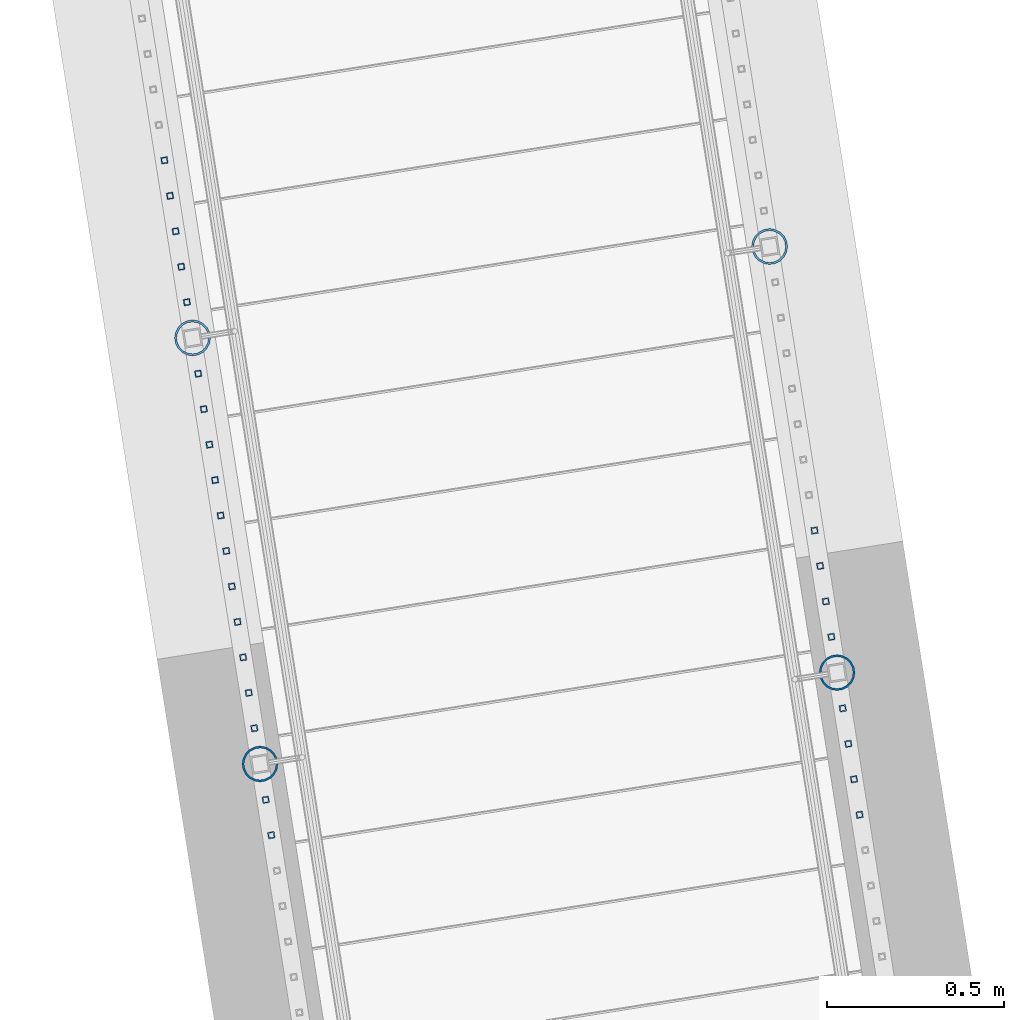
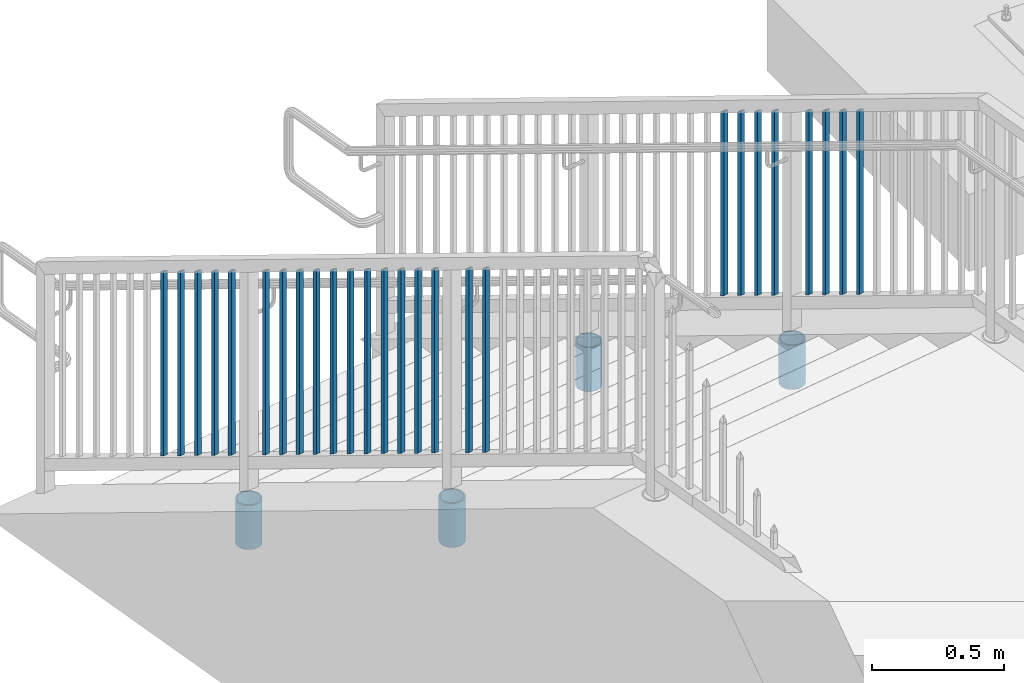
# One storey, part 228 of 975: 30 columns.
"""IFC2X3 building model written with IfcOpenShell, lengths in millimetres."""

from ifc_helpers import new_model, si_unit, frame, origin_with_axes, place, context, subcontext, project, spatial, faceted_brep, material, type_object, element, save


model = new_model("IFC2X3")

# Units and contexts
model_context = context("Model", 3, precision=1e-05, world=origin_with_axes())
body_context = subcontext(model_context, "Body", "Model", "MODEL_VIEW")
ifc_project = project(units=[si_unit("LENGTHUNIT", "METRE", prefix="MILLI"), si_unit("AREAUNIT", "SQUARE_METRE"), si_unit("VOLUMEUNIT", "CUBIC_METRE"), si_unit("MASSUNIT", "GRAM", prefix="KILO"), si_unit("TIMEUNIT", "SECOND"), si_unit("PLANEANGLEUNIT", "RADIAN"), si_unit("SOLIDANGLEUNIT", "STERADIAN"), si_unit("THERMODYNAMICTEMPERATUREUNIT", "DEGREE_CELSIUS"), si_unit("LUMINOUSINTENSITYUNIT", "LUMEN")], contexts=[model_context])

# Site, building, storey
site_placement = place(None, origin_with_axes())
site = spatial("IfcSite", under=ifc_project, at=site_placement, CompositionType="ELEMENT")
building_placement = place(site_placement, origin_with_axes())
building = spatial("IfcBuilding", under=site, at=building_placement, Name="Undefined", CompositionType="ELEMENT")
storey_placement = place(building_placement, origin_with_axes())
storey = spatial("IfcBuildingStorey", under=building, at=storey_placement, Name="Undefined", CompositionType="ELEMENT", Elevation=0.0)

# Columns
ifc_material_1 = material()
column_type_1 = type_object("IfcColumnType", Name="HSS3/4X3/4X.120_TUBES", PredefinedType="NOTDEFINED")
for number, where, z_axis, x_axis, name in (
    (1, (-937.327056312851, 27077.1870776423, 1323.36877434851), (-0.987688340611262, -0.156434464938429, 0.0), (0.0, 0.0, 1.0), "PICKET"),
    (2, (-921.455125956843, 26976.9756534569, 1379.38346680223), (-0.987688340611262, -0.156434464938429, 0.0), (0.0, 0.0, 1.0), "PICKET"),
    (3, (-905.583195600835, 26876.7642292715, 1435.39815925594), (-0.987688340611262, -0.156434464938429, 0.0), (0.0, 0.0, 1.0), "PICKET"),
    (4, (-889.711265244827, 26776.5528050861, 1491.41285170965), (-0.987688340611262, -0.156434464938429, 0.0), (0.0, 0.0, 1.0), "PICKET"),
    (5, (-857.70563819234, 26574.4772290891, 1604.36605374947), (-0.987688340611262, -0.156434464938429, 0.0), (0.0, 0.0, 1.0), "PICKET"),
    (6, (-841.833707836332, 26474.2658049037, 1660.38074620319), (-0.987688340611262, -0.156434464938429, 0.0), (0.0, 0.0, 1.0), "PICKET"),
    (7, (-825.961777480323, 26374.0543807183, 1716.3954386569), (-0.987688340611262, -0.156434464938429, 0.0), (0.0, 0.0, 1.0), "PICKET"),
    (8, (-810.089847124314, 26273.842956533, 1772.41013111062), (-0.987688340611262, -0.156434464938429, 0.0), (0.0, 0.0, 1.0), "PICKET"),
):
    element("IfcColumn", number, at=place(storey_placement, frame(where, z_axis=z_axis, x_axis=x_axis)), inside=storey, type_object=column_type_1, material=ifc_material_1, Name=name, ObjectType="HSS3/4X3/4X.120_TUBES", context=body_context, shape_type="Brep", body=[
        faceted_brep([(-3.50571911954194, 6.34999999999491, -6.34999999999809), (3.50573940444565, -6.34999999999491, -6.34999999999991), (852.681084613786, -6.34999999999491, -6.34999999999991), (845.669626084644, 6.34999999999491, -6.34999999999809), (3.50571915819046, -6.34999999998763, 6.34999999999786), (852.681084601087, -6.34999999998763, 6.34999999999786), (-3.50573936579713, 6.34999999999854, 6.34999999999968), (845.669626071945, 6.34999999999854, 6.34999999999968), (-5.25857868897492, 9.5249999999869, -9.52499999999668), (-5.25860905835771, 9.52500000000146, 9.52499999999964), (843.916761436485, 9.52500000000146, 9.52499999999964), (843.916761455533, 9.5249999999869, -9.52499999999668), (5.25857872762344, -9.52499999998327, 9.52499999999645), (854.433949230198, -9.52499999998327, 9.52499999999645), (5.25860909700623, -9.52499999999418, -9.52499999999986), (854.433949249247, -9.52499999999418, -9.52499999999986)], [[[0, 1, 2, 3]], [[1, 4, 5, 2]], [[4, 6, 7, 5]], [[6, 0, 3, 7]], [[8, 9, 10, 11]], [[9, 12, 13, 10]], [[12, 14, 15, 13]], [[14, 8, 11, 15]], [[13, 15, 11, 10], [5, 7, 3, 2]], [[14, 12, 9, 8], [6, 4, 1, 0]]]),
    ])
for number, where, z_axis, x_axis, name in (
    (9, (-2774.79150422061, 28123.2839676365, 594.692336159517), (-0.987688340611262, -0.156434464938429, 0.0), (0.0, 0.0, 1.0), "PICKET"),
    (10, (-2758.91957386478, 28023.0725434514, 650.707028613229), (-0.987688340611262, -0.156434464938429, 0.0), (0.0, 0.0, 1.0), "PICKET"),
    (11, (-2743.04764350896, 27922.8611192662, 706.721721066939), (-0.987688340611262, -0.156434464938429, 0.0), (0.0, 0.0, 1.0), "PICKET"),
    (12, (-2727.17571315313, 27822.6496950811, 762.736413520653), (-0.987688340611262, -0.156434464938429, 0.0), (0.0, 0.0, 1.0), "PICKET"),
):
    element("IfcColumn", number, at=place(storey_placement, frame(where, z_axis=z_axis, x_axis=x_axis)), inside=storey, type_object=column_type_1, material=ifc_material_1, Name=name, ObjectType="HSS3/4X3/4X.120_TUBES", context=body_context, shape_type="Brep", body=[
        faceted_brep([(-3.94394580574479, 6.34999999999127, -6.349999999999), (3.06751272214467, -6.34999999999491, -6.35000000000082), (852.242827714489, -6.34999999999491, -6.35000000000082), (845.231369186599, 6.34999999999127, -6.349999999999), (3.06751272214575, -6.34999999999127, 6.34999999999764), (852.24282771449, -6.34999999999127, 6.34999999999764), (-3.94394580574374, 6.34999999999854, 6.34999999999991), (845.2313691866, 6.34999999999854, 6.34999999999991), (-5.69681043771743, 9.5249999999869, -9.52499999999736), (-5.69681043771581, 9.52499999999782, 9.52499999999918), (843.478504554628, 9.52499999999782, 9.52499999999918), (843.478504554626, 9.5249999999869, -9.52499999999736), (4.82037735411836, -9.5249999999869, 9.52499999999645), (853.995692346462, -9.5249999999869, 9.52499999999645), (4.82037735411677, -9.52499999999782, -9.52500000000055), (853.995692346461, -9.52499999999782, -9.52500000000055)], [[[0, 1, 2, 3]], [[1, 4, 5, 2]], [[4, 6, 7, 5]], [[6, 0, 3, 7]], [[8, 9, 10, 11]], [[9, 12, 13, 10]], [[12, 14, 15, 13]], [[14, 8, 11, 15]], [[13, 15, 11, 10], [5, 7, 3, 2]], [[14, 12, 9, 8], [6, 4, 1, 0]]]),
    ])
column_1_placement = place(storey_placement, frame((-2711.30378279731, 27722.438270896, 833.237042974365), z_axis=(-0.987688340611262, -0.156434464938429, 0.0), x_axis=(0.0, 0.0, 1.0)))
element("IfcColumn", 13, at=column_1_placement, inside=storey, type_object=column_type_1, material=ifc_material_1, Name="PICKET", ObjectType="HSS3/4X3/4X.120_TUBES", context=body_context, shape_type="Brep", body=[
    faceted_brep([(-18.4298827920588, 6.34999999999127, -6.35000000000127), (-11.4184242641691, -6.34999999999854, -6.34999999999991), (837.756890723162, -6.34999999999854, -6.34999999999991), (830.745432195272, 6.34999999999127, -6.35000000000127), (-11.4184242641696, -6.34999999999127, 6.35000000000127), (837.756890723162, -6.34999999999127, 6.35000000000127), (-18.4298827920593, 6.34999999999491, 6.35000000000036), (830.745432195272, 6.34999999999491, 6.35000000000036), (-20.182747424031, 9.5249999999869, -9.52500000000055), (-20.1827474240318, 9.52499999999782, 9.52500000000009), (828.992567563299, 9.52499999999782, 9.52500000000009), (828.9925675633, 9.5249999999869, -9.52500000000055), (-9.6655596321973, -9.5249999999869, 9.525000000001), (839.509755355134, -9.5249999999869, 9.525000000001), (-9.6655596321965, -9.52500000000146, -9.52499999999964), (839.509755355135, -9.52500000000146, -9.52499999999964)], [[[0, 1, 2, 3]], [[1, 4, 5, 2]], [[4, 6, 7, 5]], [[6, 0, 3, 7]], [[8, 9, 10, 11]], [[9, 12, 13, 10]], [[12, 14, 15, 13]], [[14, 8, 11, 15]], [[13, 15, 11, 10], [5, 7, 3, 2]], [[14, 12, 9, 8], [6, 4, 1, 0]]]),
])
for number, where, z_axis, x_axis, name in (
    (14, (-2679.29820240959, 27520.3629895268, 931.265927172524), (-0.987688340611262, -0.156434464938429, 0.0), (0.0, 0.0, 1.0), "PICKET"),
    (15, (-2663.42627205376, 27420.1515653416, 987.280619626236), (-0.987688340611262, -0.156434464938429, 0.0), (0.0, 0.0, 1.0), "PICKET"),
    (16, (-2647.55434169794, 27319.9401411565, 1043.29531207995), (-0.987688340611262, -0.156434464938429, 0.0), (0.0, 0.0, 1.0), "PICKET"),
    (17, (-2631.68241134212, 27219.7287169714, 1099.31000453366), (-0.987688340611262, -0.156434464938429, 0.0), (0.0, 0.0, 1.0), "PICKET"),
    (18, (-2615.81048098629, 27119.5172927862, 1155.32469698738), (-0.987688340611262, -0.156434464938429, 0.0), (0.0, 0.0, 1.0), "PICKET"),
    (19, (-2599.93855063047, 27019.3058686011, 1211.33938944109), (-0.987688340611262, -0.156434464938429, 0.0), (0.0, 0.0, 1.0), "PICKET"),
    (20, (-2584.06662027464, 26919.094444416, 1267.3540818948), (-0.987688340611262, -0.156434464938429, 0.0), (0.0, 0.0, 1.0), "PICKET"),
    (21, (-2568.19468991882, 26818.8830202308, 1323.36877434851), (-0.987688340611262, -0.156434464938429, 0.0), (0.0, 0.0, 1.0), "PICKET"),
    (22, (-2552.32275956299, 26718.6715960457, 1379.38346680223), (-0.987688340611262, -0.156434464938429, 0.0), (0.0, 0.0, 1.0), "PICKET"),
    (23, (-2536.45082920717, 26618.4601718606, 1435.39815925594), (-0.987688340611262, -0.156434464938429, 0.0), (0.0, 0.0, 1.0), "PICKET"),
    (24, (-2520.57889885134, 26518.2487476754, 1491.41285170965), (-0.987688340611262, -0.156434464938429, 0.0), (0.0, 0.0, 1.0), "PICKET"),
    (25, (-2488.57327179923, 26316.1731716789, 1604.36605374947), (-0.987688340611262, -0.156434464938429, 0.0), (0.0, 0.0, 1.0), "PICKET"),
    (26, (-2472.7013414434, 26215.9617474937, 1660.38074620319), (-0.987688340611262, -0.156434464938429, 0.0), (0.0, 0.0, 1.0), "PICKET"),
):
    element("IfcColumn", number, at=place(storey_placement, frame(where, z_axis=z_axis, x_axis=x_axis)), inside=storey, type_object=column_type_1, material=ifc_material_1, Name=name, ObjectType="HSS3/4X3/4X.120_TUBES", context=body_context, shape_type="Brep", body=[
        faceted_brep([(-3.50571911954194, 6.34999999999491, -6.34999999999809), (3.50573940444565, -6.34999999999491, -6.34999999999991), (852.681084613786, -6.34999999999491, -6.34999999999991), (845.669626084644, 6.34999999999491, -6.34999999999809), (3.50571915819046, -6.34999999998763, 6.34999999999786), (852.681084601087, -6.34999999998763, 6.34999999999786), (-3.50573936579713, 6.34999999999854, 6.34999999999968), (845.669626071945, 6.34999999999854, 6.34999999999968), (-5.25857868897492, 9.5249999999869, -9.52499999999668), (-5.25860905835771, 9.52500000000146, 9.52499999999964), (843.916761436485, 9.52500000000146, 9.52499999999964), (843.916761455533, 9.5249999999869, -9.52499999999668), (5.25857872762344, -9.52499999998327, 9.52499999999645), (854.433949230198, -9.52499999998327, 9.52499999999645), (5.25860909700623, -9.52499999999418, -9.52499999999986), (854.433949249247, -9.52499999999418, -9.52499999999986)], [[[0, 1, 2, 3]], [[1, 4, 5, 2]], [[4, 6, 7, 5]], [[6, 0, 3, 7]], [[8, 9, 10, 11]], [[9, 12, 13, 10]], [[12, 14, 15, 13]], [[14, 8, 11, 15]], [[13, 15, 11, 10], [5, 7, 3, 2]], [[14, 12, 9, 8], [6, 4, 1, 0]]]),
    ])
ifc_material_2 = material(Name="STEEL/A53")
column_type_2 = type_object("IfcColumnType", Name="PIPE3-1/2STD", PredefinedType="NOTDEFINED")
column_2_placement = place(storey_placement, frame((-1064.4406300493, 27879.7468273691, 469.900035183466), z_axis=(0.587785252279345, 0.809016994384486, -8.09014238711826e-10), x_axis=(0.0, 0.0, 1.0)))
element("IfcColumn", 27, at=column_2_placement, inside=storey, type_object=column_type_2, material=ifc_material_2, ObjectType="PIPE3-1/2STD", context=body_context, shape_type="Brep", body=[
    faceted_brep([(0.0, -45.0595999999932, 1.45519152283669e-11), (0.0, -42.8542262016344, 13.924182159768), (203.199999999991, -42.8542262017145, 13.9241821598171), (203.19999999999, -45.0596000000478, 5.82076609134674e-11), (0.0, -36.45398215971, 26.4853683542424), (203.199999999993, -36.45398215981, 26.4853683542988), (0.0, -26.4853683541623, 36.45398215979), (203.199999999995, -26.4853683542788, 36.4539821598537), (0.0, -13.9241821596988, 42.8542262017108), (203.199999999998, -13.9241821598262, 42.8542262017836), (0.0, 3.63797880709171e-11, 45.0596000000514), (203.2, -9.27684595808387e-11, 45.0596000001387), (0.0, 13.9241821597716, 42.8542262017036), (203.200000000003, 13.9241821596443, 42.8542262017927), (0.0, 26.4853683542242, 36.4539821597718), (203.200000000006, 26.4853683541096, 36.4539821598701), (0.0, 36.4539821597537, 26.4853683542206), (203.200000000008, 36.4539821596554, 26.4853683543224), (0.0, 42.8542262016563, 13.9241821597425), (203.200000000009, 42.8542262015817, 13.9241821598443), (0.0, 45.0595999999932, -1.09139364212751e-11), (203.200000000009, 45.0595999999423, 8.9130480773747e-11), (0.0, 42.8542262016344, -13.9241821597643), (203.200000000008, 42.854226201609, -13.9241821596697), (0.0, 36.45398215971, -26.4853683542387), (203.200000000007, 36.4539821597045, -26.4853683541514), (0.0, 26.4853683541623, -36.4539821597864), (203.200000000004, 26.4853683541733, -36.4539821597064), (0.0, 13.9241821596988, -42.8542262017072), (203.200000000002, 13.9241821597225, -42.8542262016381), (0.0, -3.63797880709171e-11, -45.0596000000478), (203.199999999999, -9.09494701772928e-12, -45.0595999999914), (0.0, -13.9241821597716, -42.8542262016963), (203.199999999996, -13.9241821597479, -42.8542262016472), (0.0, -26.4853683542242, -36.4539821597682), (203.199999999993, -26.4853683542133, -36.4539821597227), (0.0, -36.4539821597537, -26.4853683542169), (203.199999999992, -36.4539821597609, -26.4853683541751), (0.0, -42.8542262016563, -13.9241821597352), (203.199999999991, -42.8542262016872, -13.924182159697), (0.0, -50.799999999992, 1.81898940354586e-11), (0.0, -48.3136710278013, -15.6980633142484), (203.199999999989, -48.313671027825, -15.6980633142139), (203.199999999989, -50.8000000000466, 5.63886715099216e-11), (0.0, -41.0980633142644, -29.8594908164741), (203.19999999999, -41.0980633142663, -29.8594908164414), (0.0, -29.859490816485, -41.0980633142826), (203.199999999993, -29.8594908164687, -41.0980633142426), (0.0, -15.6980633142848, -48.313671027845), (203.199999999995, -15.6980633142539, -48.313671027794), (0.0, -4.36557456851006e-11, -50.8000000000575), (203.199999999998, -7.27595761418343e-12, -50.7999999999993), (0.0, 15.6980633142011, -48.3136710278523), (203.200000000002, 15.6980633142375, -48.3136710277831), (0.0, 29.8594908164159, -41.0980633143045), (203.200000000005, 29.8594908164378, -41.0980633142226), (0.0, 41.0980633142135, -29.8594908165032), (203.200000000008, 41.0980633142171, -29.8594908164141), (0.0, 48.3136710277722, -15.6980633142775), (203.200000000009, 48.3136710277504, -15.6980633141811), (0.0, 50.799999999992, -1.45519152283669e-11), (203.20000000001, 50.7999999999411, 9.09494701772928e-11), (0.0, 48.313671027794, 15.6980633142521), (203.20000000001, 48.3136710277213, 15.6980633143594), (0.0, 41.0980633142644, 29.8594908164814), (203.200000000008, 41.0980633141626, 29.8594908165887), (0.0, 29.859490816485, 41.0980633142863), (203.200000000007, 29.8594908163632, 41.0980633143899), (0.0, 15.6980633142848, 48.3136710278486), (203.200000000004, 15.6980633141484, 48.3136710279414), (0.0, 4.00177668780088e-11, 50.8000000000611), (203.200000000001, -9.82254277914762e-11, 50.8000000001466), (0.0, -15.6980633142011, 48.3136710278559), (203.199999999997, -15.698063314343, 48.3136710279305), (0.0, -29.8594908164159, 41.0980633143081), (203.199999999994, -29.8594908165433, 41.0980633143681), (0.0, -41.0980633142171, 29.8594908165069), (203.199999999992, -41.0980633143226, 29.8594908165596), (0.0, -48.3136710277722, 15.6980633142812), (203.19999999999, -48.3136710278559, 15.6980633143285)], [[[0, 1, 2, 3]], [[1, 4, 5, 2]], [[4, 6, 7, 5]], [[6, 8, 9, 7]], [[8, 10, 11, 9]], [[10, 12, 13, 11]], [[12, 14, 15, 13]], [[14, 16, 17, 15]], [[16, 18, 19, 17]], [[18, 20, 21, 19]], [[20, 22, 23, 21]], [[22, 24, 25, 23]], [[24, 26, 27, 25]], [[26, 28, 29, 27]], [[28, 30, 31, 29]], [[30, 32, 33, 31]], [[32, 34, 35, 33]], [[34, 36, 37, 35]], [[36, 38, 39, 37]], [[38, 0, 3, 39]], [[40, 41, 42, 43]], [[41, 44, 45, 42]], [[44, 46, 47, 45]], [[46, 48, 49, 47]], [[48, 50, 51, 49]], [[50, 52, 53, 51]], [[52, 54, 55, 53]], [[54, 56, 57, 55]], [[56, 58, 59, 57]], [[58, 60, 61, 59]], [[60, 62, 63, 61]], [[62, 64, 65, 63]], [[64, 66, 67, 65]], [[66, 68, 69, 67]], [[68, 70, 71, 69]], [[70, 72, 73, 71]], [[72, 74, 75, 73]], [[74, 76, 77, 75]], [[76, 78, 79, 77]], [[78, 40, 43, 79]], [[45, 47, 49, 51, 53, 55, 57, 59, 61, 63, 65, 67, 69, 71, 73, 75, 77, 79, 43, 42], [5, 7, 9, 11, 13, 15, 17, 19, 21, 23, 25, 27, 29, 31, 33, 35, 37, 39, 3, 2]], [[78, 76, 74, 72, 70, 68, 66, 64, 62, 60, 58, 56, 54, 52, 50, 48, 46, 44, 41, 40], [38, 36, 34, 32, 30, 28, 26, 24, 22, 20, 18, 16, 14, 12, 10, 8, 6, 4, 1, 0]]]),
])
column_3_placement = place(storey_placement, frame((-873.715746490077, 26675.5573041208, 1143.00013283972), z_axis=(0.587785252279345, 0.809016994384486, -8.09014238711826e-10), x_axis=(0.0, 0.0, 1.0)))
element("IfcColumn", 28, at=column_3_placement, inside=storey, type_object=column_type_2, material=ifc_material_2, ObjectType="PIPE3-1/2STD", context=body_context, shape_type="Brep", body=[
    faceted_brep([(0.0, -45.0595999999932, 1.45519152283669e-11), (0.0, -42.8542262016344, 13.924182159768), (203.199999999991, -42.8542262017145, 13.9241821598171), (203.19999999999, -45.0596000000478, 5.82076609134674e-11), (0.0, -36.45398215971, 26.4853683542424), (203.199999999993, -36.45398215981, 26.4853683542988), (0.0, -26.4853683541623, 36.45398215979), (203.199999999995, -26.4853683542788, 36.4539821598537), (0.0, -13.9241821596988, 42.8542262017108), (203.199999999998, -13.9241821598262, 42.8542262017836), (0.0, 3.63797880709171e-11, 45.0596000000514), (203.2, -9.27684595808387e-11, 45.0596000001387), (0.0, 13.9241821597716, 42.8542262017036), (203.200000000003, 13.9241821596443, 42.8542262017927), (0.0, 26.4853683542242, 36.4539821597718), (203.200000000006, 26.4853683541096, 36.4539821598701), (0.0, 36.4539821597537, 26.4853683542206), (203.200000000008, 36.4539821596554, 26.4853683543224), (0.0, 42.8542262016563, 13.9241821597425), (203.200000000009, 42.8542262015817, 13.9241821598443), (0.0, 45.0595999999932, -1.09139364212751e-11), (203.200000000009, 45.0595999999423, 8.9130480773747e-11), (0.0, 42.8542262016344, -13.9241821597643), (203.200000000008, 42.854226201609, -13.9241821596697), (0.0, 36.45398215971, -26.4853683542387), (203.200000000007, 36.4539821597045, -26.4853683541514), (0.0, 26.4853683541623, -36.4539821597864), (203.200000000004, 26.4853683541733, -36.4539821597064), (0.0, 13.9241821596988, -42.8542262017072), (203.200000000002, 13.9241821597225, -42.8542262016381), (0.0, -3.63797880709171e-11, -45.0596000000478), (203.199999999999, -9.09494701772928e-12, -45.0595999999914), (0.0, -13.9241821597716, -42.8542262016963), (203.199999999996, -13.9241821597479, -42.8542262016472), (0.0, -26.4853683542242, -36.4539821597682), (203.199999999993, -26.4853683542133, -36.4539821597227), (0.0, -36.4539821597537, -26.4853683542169), (203.199999999992, -36.4539821597609, -26.4853683541751), (0.0, -42.8542262016563, -13.9241821597352), (203.199999999991, -42.8542262016872, -13.924182159697), (0.0, -50.799999999992, 1.81898940354586e-11), (0.0, -48.3136710278013, -15.6980633142484), (203.199999999989, -48.313671027825, -15.6980633142139), (203.199999999989, -50.8000000000466, 5.63886715099216e-11), (0.0, -41.0980633142644, -29.8594908164741), (203.19999999999, -41.0980633142663, -29.8594908164414), (0.0, -29.859490816485, -41.0980633142826), (203.199999999993, -29.8594908164687, -41.0980633142426), (0.0, -15.6980633142848, -48.313671027845), (203.199999999995, -15.6980633142539, -48.313671027794), (0.0, -4.36557456851006e-11, -50.8000000000575), (203.199999999998, -7.27595761418343e-12, -50.7999999999993), (0.0, 15.6980633142011, -48.3136710278523), (203.200000000002, 15.6980633142375, -48.3136710277831), (0.0, 29.8594908164159, -41.0980633143045), (203.200000000005, 29.8594908164378, -41.0980633142226), (0.0, 41.0980633142135, -29.8594908165032), (203.200000000008, 41.0980633142171, -29.8594908164141), (0.0, 48.3136710277722, -15.6980633142775), (203.200000000009, 48.3136710277504, -15.6980633141811), (0.0, 50.799999999992, -1.45519152283669e-11), (203.20000000001, 50.7999999999411, 9.09494701772928e-11), (0.0, 48.313671027794, 15.6980633142521), (203.20000000001, 48.3136710277213, 15.6980633143594), (0.0, 41.0980633142644, 29.8594908164814), (203.200000000008, 41.0980633141626, 29.8594908165887), (0.0, 29.859490816485, 41.0980633142863), (203.200000000007, 29.8594908163632, 41.0980633143899), (0.0, 15.6980633142848, 48.3136710278486), (203.200000000004, 15.6980633141484, 48.3136710279414), (0.0, 4.00177668780088e-11, 50.8000000000611), (203.200000000001, -9.82254277914762e-11, 50.8000000001466), (0.0, -15.6980633142011, 48.3136710278559), (203.199999999997, -15.698063314343, 48.3136710279305), (0.0, -29.8594908164159, 41.0980633143081), (203.199999999994, -29.8594908165433, 41.0980633143681), (0.0, -41.0980633142171, 29.8594908165069), (203.199999999992, -41.0980633143226, 29.8594908165596), (0.0, -48.3136710277722, 15.6980633142812), (203.19999999999, -48.3136710278559, 15.6980633143285)], [[[0, 1, 2, 3]], [[1, 4, 5, 2]], [[4, 6, 7, 5]], [[6, 8, 9, 7]], [[8, 10, 11, 9]], [[10, 12, 13, 11]], [[12, 14, 15, 13]], [[14, 16, 17, 15]], [[16, 18, 19, 17]], [[18, 20, 21, 19]], [[20, 22, 23, 21]], [[22, 24, 25, 23]], [[24, 26, 27, 25]], [[26, 28, 29, 27]], [[28, 30, 31, 29]], [[30, 32, 33, 31]], [[32, 34, 35, 33]], [[34, 36, 37, 35]], [[36, 38, 39, 37]], [[38, 0, 3, 39]], [[40, 41, 42, 43]], [[41, 44, 45, 42]], [[44, 46, 47, 45]], [[46, 48, 49, 47]], [[48, 50, 51, 49]], [[50, 52, 53, 51]], [[52, 54, 55, 53]], [[54, 56, 57, 55]], [[56, 58, 59, 57]], [[58, 60, 61, 59]], [[60, 62, 63, 61]], [[62, 64, 65, 63]], [[64, 66, 67, 65]], [[66, 68, 69, 67]], [[68, 70, 71, 69]], [[70, 72, 73, 71]], [[72, 74, 75, 73]], [[74, 76, 77, 75]], [[76, 78, 79, 77]], [[78, 40, 43, 79]], [[45, 47, 49, 51, 53, 55, 57, 59, 61, 63, 65, 67, 69, 71, 73, 75, 77, 79, 43, 42], [5, 7, 9, 11, 13, 15, 17, 19, 21, 23, 25, 27, 29, 31, 33, 35, 37, 39, 3, 2]], [[78, 76, 74, 72, 70, 68, 66, 64, 62, 60, 58, 56, 54, 52, 50, 48, 46, 44, 41, 40], [38, 36, 34, 32, 30, 28, 26, 24, 22, 20, 18, 16, 14, 12, 10, 8, 6, 4, 1, 0]]]),
])
column_4_placement = place(storey_placement, frame((-2695.30752030039, 27621.4428946955, 469.900035183466), z_axis=(-0.587785252279345, -0.809016994384486, -8.09014181868407e-10), x_axis=(0.0, 0.0, 1.0)))
element("IfcColumn", 29, at=column_4_placement, inside=storey, type_object=column_type_2, material=ifc_material_2, ObjectType="PIPE3-1/2STD", context=body_context, shape_type="Brep", body=[
    faceted_brep([(0.0, -45.0595999999932, 1.45519152283669e-11), (0.0, -42.8542262016344, 13.924182159768), (203.199999999991, -42.8542262017145, 13.9241821598171), (203.19999999999, -45.0596000000478, 5.82076609134674e-11), (0.0, -36.45398215971, 26.4853683542424), (203.199999999993, -36.45398215981, 26.4853683542988), (0.0, -26.4853683541623, 36.45398215979), (203.199999999995, -26.4853683542788, 36.4539821598537), (0.0, -13.9241821596988, 42.8542262017108), (203.199999999998, -13.9241821598262, 42.8542262017836), (0.0, 3.63797880709171e-11, 45.0596000000514), (203.2, -9.27684595808387e-11, 45.0596000001387), (0.0, 13.9241821597716, 42.8542262017036), (203.200000000003, 13.9241821596443, 42.8542262017927), (0.0, 26.4853683542242, 36.4539821597718), (203.200000000006, 26.4853683541096, 36.4539821598701), (0.0, 36.4539821597537, 26.4853683542206), (203.200000000008, 36.4539821596554, 26.4853683543224), (0.0, 42.8542262016563, 13.9241821597425), (203.200000000009, 42.8542262015817, 13.9241821598443), (0.0, 45.0595999999932, -1.09139364212751e-11), (203.200000000009, 45.0595999999423, 8.9130480773747e-11), (0.0, 42.8542262016344, -13.9241821597643), (203.200000000008, 42.854226201609, -13.9241821596697), (0.0, 36.45398215971, -26.4853683542387), (203.200000000007, 36.4539821597045, -26.4853683541514), (0.0, 26.4853683541623, -36.4539821597864), (203.200000000004, 26.4853683541733, -36.4539821597064), (0.0, 13.9241821596988, -42.8542262017072), (203.200000000002, 13.9241821597225, -42.8542262016381), (0.0, -3.63797880709171e-11, -45.0596000000478), (203.199999999999, -9.09494701772928e-12, -45.0595999999914), (0.0, -13.9241821597716, -42.8542262016963), (203.199999999996, -13.9241821597479, -42.8542262016472), (0.0, -26.4853683542242, -36.4539821597682), (203.199999999993, -26.4853683542133, -36.4539821597227), (0.0, -36.4539821597537, -26.4853683542169), (203.199999999992, -36.4539821597609, -26.4853683541751), (0.0, -42.8542262016563, -13.9241821597352), (203.199999999991, -42.8542262016872, -13.924182159697), (0.0, -50.799999999992, 1.81898940354586e-11), (0.0, -48.3136710278013, -15.6980633142484), (203.199999999989, -48.313671027825, -15.6980633142139), (203.199999999989, -50.8000000000466, 5.63886715099216e-11), (0.0, -41.0980633142644, -29.8594908164741), (203.19999999999, -41.0980633142663, -29.8594908164414), (0.0, -29.859490816485, -41.0980633142826), (203.199999999993, -29.8594908164687, -41.0980633142426), (0.0, -15.6980633142848, -48.313671027845), (203.199999999995, -15.6980633142539, -48.313671027794), (0.0, -4.36557456851006e-11, -50.8000000000575), (203.199999999998, -7.27595761418343e-12, -50.7999999999993), (0.0, 15.6980633142011, -48.3136710278523), (203.200000000002, 15.6980633142375, -48.3136710277831), (0.0, 29.8594908164159, -41.0980633143045), (203.200000000005, 29.8594908164378, -41.0980633142226), (0.0, 41.0980633142135, -29.8594908165032), (203.200000000008, 41.0980633142171, -29.8594908164141), (0.0, 48.3136710277722, -15.6980633142775), (203.200000000009, 48.3136710277504, -15.6980633141811), (0.0, 50.799999999992, -1.45519152283669e-11), (203.20000000001, 50.7999999999411, 9.09494701772928e-11), (0.0, 48.313671027794, 15.6980633142521), (203.20000000001, 48.3136710277213, 15.6980633143594), (0.0, 41.0980633142644, 29.8594908164814), (203.200000000008, 41.0980633141626, 29.8594908165887), (0.0, 29.859490816485, 41.0980633142863), (203.200000000007, 29.8594908163632, 41.0980633143899), (0.0, 15.6980633142848, 48.3136710278486), (203.200000000004, 15.6980633141484, 48.3136710279414), (0.0, 4.00177668780088e-11, 50.8000000000611), (203.200000000001, -9.82254277914762e-11, 50.8000000001466), (0.0, -15.6980633142011, 48.3136710278559), (203.199999999997, -15.698063314343, 48.3136710279305), (0.0, -29.8594908164159, 41.0980633143081), (203.199999999994, -29.8594908165433, 41.0980633143681), (0.0, -41.0980633142171, 29.8594908165069), (203.199999999992, -41.0980633143226, 29.8594908165596), (0.0, -48.3136710277722, 15.6980633142812), (203.19999999999, -48.3136710278559, 15.6980633143285)], [[[0, 1, 2, 3]], [[1, 4, 5, 2]], [[4, 6, 7, 5]], [[6, 8, 9, 7]], [[8, 10, 11, 9]], [[10, 12, 13, 11]], [[12, 14, 15, 13]], [[14, 16, 17, 15]], [[16, 18, 19, 17]], [[18, 20, 21, 19]], [[20, 22, 23, 21]], [[22, 24, 25, 23]], [[24, 26, 27, 25]], [[26, 28, 29, 27]], [[28, 30, 31, 29]], [[30, 32, 33, 31]], [[32, 34, 35, 33]], [[34, 36, 37, 35]], [[36, 38, 39, 37]], [[38, 0, 3, 39]], [[40, 41, 42, 43]], [[41, 44, 45, 42]], [[44, 46, 47, 45]], [[46, 48, 49, 47]], [[48, 50, 51, 49]], [[50, 52, 53, 51]], [[52, 54, 55, 53]], [[54, 56, 57, 55]], [[56, 58, 59, 57]], [[58, 60, 61, 59]], [[60, 62, 63, 61]], [[62, 64, 65, 63]], [[64, 66, 67, 65]], [[66, 68, 69, 67]], [[68, 70, 71, 69]], [[70, 72, 73, 71]], [[72, 74, 75, 73]], [[74, 76, 77, 75]], [[76, 78, 79, 77]], [[78, 40, 43, 79]], [[45, 47, 49, 51, 53, 55, 57, 59, 61, 63, 65, 67, 69, 71, 73, 75, 77, 79, 43, 42], [5, 7, 9, 11, 13, 15, 17, 19, 21, 23, 25, 27, 29, 31, 33, 35, 37, 39, 3, 2]], [[78, 76, 74, 72, 70, 68, 66, 64, 62, 60, 58, 56, 54, 52, 50, 48, 46, 44, 41, 40], [38, 36, 34, 32, 30, 28, 26, 24, 22, 20, 18, 16, 14, 12, 10, 8, 6, 4, 1, 0]]]),
])
column_5_placement = place(storey_placement, frame((-2504.58263674227, 26417.2533714433, 1143.00013283972), z_axis=(-0.587785252279345, -0.809016994384486, -8.09014181868407e-10), x_axis=(0.0, 0.0, 1.0)))
element("IfcColumn", 30, at=column_5_placement, inside=storey, type_object=column_type_2, material=ifc_material_2, ObjectType="PIPE3-1/2STD", context=body_context, shape_type="Brep", body=[
    faceted_brep([(0.0, -45.0595999999932, 1.45519152283669e-11), (0.0, -42.8542262016344, 13.924182159768), (203.199999999991, -42.8542262017145, 13.9241821598171), (203.19999999999, -45.0596000000478, 5.82076609134674e-11), (0.0, -36.45398215971, 26.4853683542424), (203.199999999993, -36.45398215981, 26.4853683542988), (0.0, -26.4853683541623, 36.45398215979), (203.199999999995, -26.4853683542788, 36.4539821598537), (0.0, -13.9241821596988, 42.8542262017108), (203.199999999998, -13.9241821598262, 42.8542262017836), (0.0, 3.63797880709171e-11, 45.0596000000514), (203.2, -9.27684595808387e-11, 45.0596000001387), (0.0, 13.9241821597716, 42.8542262017036), (203.200000000003, 13.9241821596443, 42.8542262017927), (0.0, 26.4853683542242, 36.4539821597718), (203.200000000006, 26.4853683541096, 36.4539821598701), (0.0, 36.4539821597537, 26.4853683542206), (203.200000000008, 36.4539821596554, 26.4853683543224), (0.0, 42.8542262016563, 13.9241821597425), (203.200000000009, 42.8542262015817, 13.9241821598443), (0.0, 45.0595999999932, -1.09139364212751e-11), (203.200000000009, 45.0595999999423, 8.9130480773747e-11), (0.0, 42.8542262016344, -13.9241821597643), (203.200000000008, 42.854226201609, -13.9241821596697), (0.0, 36.45398215971, -26.4853683542387), (203.200000000007, 36.4539821597045, -26.4853683541514), (0.0, 26.4853683541623, -36.4539821597864), (203.200000000004, 26.4853683541733, -36.4539821597064), (0.0, 13.9241821596988, -42.8542262017072), (203.200000000002, 13.9241821597225, -42.8542262016381), (0.0, -3.63797880709171e-11, -45.0596000000478), (203.199999999999, -9.09494701772928e-12, -45.0595999999914), (0.0, -13.9241821597716, -42.8542262016963), (203.199999999996, -13.9241821597479, -42.8542262016472), (0.0, -26.4853683542242, -36.4539821597682), (203.199999999993, -26.4853683542133, -36.4539821597227), (0.0, -36.4539821597537, -26.4853683542169), (203.199999999992, -36.4539821597609, -26.4853683541751), (0.0, -42.8542262016563, -13.9241821597352), (203.199999999991, -42.8542262016872, -13.924182159697), (0.0, -50.799999999992, 1.81898940354586e-11), (0.0, -48.3136710278013, -15.6980633142484), (203.199999999989, -48.313671027825, -15.6980633142139), (203.199999999989, -50.8000000000466, 5.63886715099216e-11), (0.0, -41.0980633142644, -29.8594908164741), (203.19999999999, -41.0980633142663, -29.8594908164414), (0.0, -29.859490816485, -41.0980633142826), (203.199999999993, -29.8594908164687, -41.0980633142426), (0.0, -15.6980633142848, -48.313671027845), (203.199999999995, -15.6980633142539, -48.313671027794), (0.0, -4.36557456851006e-11, -50.8000000000575), (203.199999999998, -7.27595761418343e-12, -50.7999999999993), (0.0, 15.6980633142011, -48.3136710278523), (203.200000000002, 15.6980633142375, -48.3136710277831), (0.0, 29.8594908164159, -41.0980633143045), (203.200000000005, 29.8594908164378, -41.0980633142226), (0.0, 41.0980633142135, -29.8594908165032), (203.200000000008, 41.0980633142171, -29.8594908164141), (0.0, 48.3136710277722, -15.6980633142775), (203.200000000009, 48.3136710277504, -15.6980633141811), (0.0, 50.799999999992, -1.45519152283669e-11), (203.20000000001, 50.7999999999411, 9.09494701772928e-11), (0.0, 48.313671027794, 15.6980633142521), (203.20000000001, 48.3136710277213, 15.6980633143594), (0.0, 41.0980633142644, 29.8594908164814), (203.200000000008, 41.0980633141626, 29.8594908165887), (0.0, 29.859490816485, 41.0980633142863), (203.200000000007, 29.8594908163632, 41.0980633143899), (0.0, 15.6980633142848, 48.3136710278486), (203.200000000004, 15.6980633141484, 48.3136710279414), (0.0, 4.00177668780088e-11, 50.8000000000611), (203.200000000001, -9.82254277914762e-11, 50.8000000001466), (0.0, -15.6980633142011, 48.3136710278559), (203.199999999997, -15.698063314343, 48.3136710279305), (0.0, -29.8594908164159, 41.0980633143081), (203.199999999994, -29.8594908165433, 41.0980633143681), (0.0, -41.0980633142171, 29.8594908165069), (203.199999999992, -41.0980633143226, 29.8594908165596), (0.0, -48.3136710277722, 15.6980633142812), (203.19999999999, -48.3136710278559, 15.6980633143285)], [[[0, 1, 2, 3]], [[1, 4, 5, 2]], [[4, 6, 7, 5]], [[6, 8, 9, 7]], [[8, 10, 11, 9]], [[10, 12, 13, 11]], [[12, 14, 15, 13]], [[14, 16, 17, 15]], [[16, 18, 19, 17]], [[18, 20, 21, 19]], [[20, 22, 23, 21]], [[22, 24, 25, 23]], [[24, 26, 27, 25]], [[26, 28, 29, 27]], [[28, 30, 31, 29]], [[30, 32, 33, 31]], [[32, 34, 35, 33]], [[34, 36, 37, 35]], [[36, 38, 39, 37]], [[38, 0, 3, 39]], [[40, 41, 42, 43]], [[41, 44, 45, 42]], [[44, 46, 47, 45]], [[46, 48, 49, 47]], [[48, 50, 51, 49]], [[50, 52, 53, 51]], [[52, 54, 55, 53]], [[54, 56, 57, 55]], [[56, 58, 59, 57]], [[58, 60, 61, 59]], [[60, 62, 63, 61]], [[62, 64, 65, 63]], [[64, 66, 67, 65]], [[66, 68, 69, 67]], [[68, 70, 71, 69]], [[70, 72, 73, 71]], [[72, 74, 75, 73]], [[74, 76, 77, 75]], [[76, 78, 79, 77]], [[78, 40, 43, 79]], [[45, 47, 49, 51, 53, 55, 57, 59, 61, 63, 65, 67, 69, 71, 73, 75, 77, 79, 43, 42], [5, 7, 9, 11, 13, 15, 17, 19, 21, 23, 25, 27, 29, 31, 33, 35, 37, 39, 3, 2]], [[78, 76, 74, 72, 70, 68, 66, 64, 62, 60, 58, 56, 54, 52, 50, 48, 46, 44, 41, 40], [38, 36, 34, 32, 30, 28, 26, 24, 22, 20, 18, 16, 14, 12, 10, 8, 6, 4, 1, 0]]]),
])

save(model, "model.ifc")
